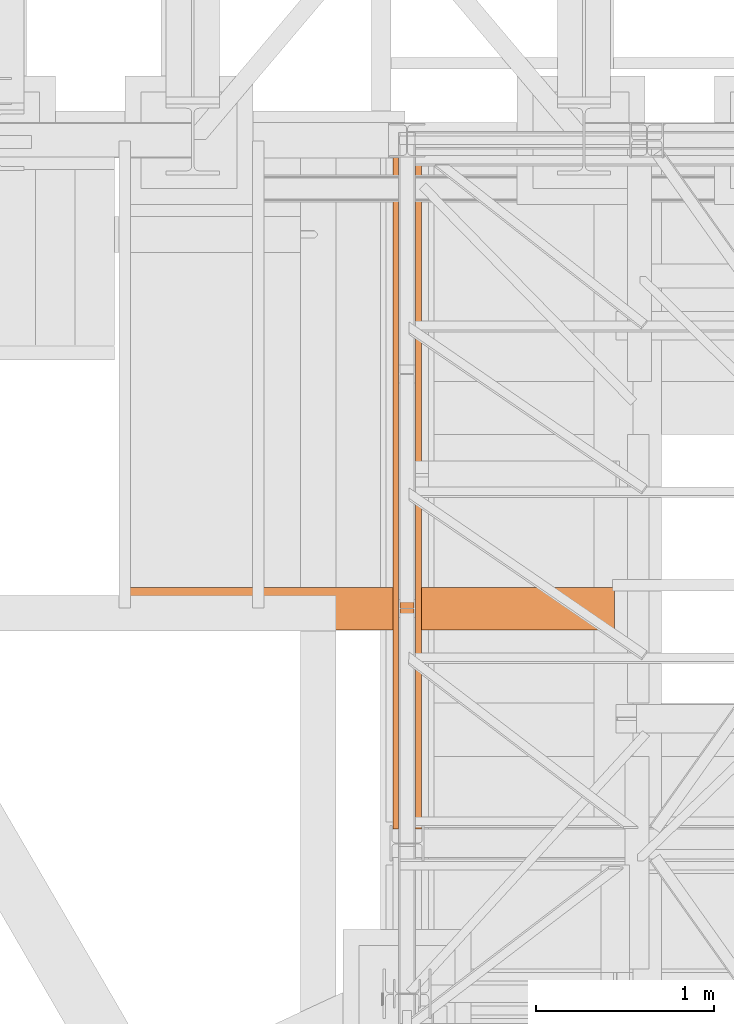
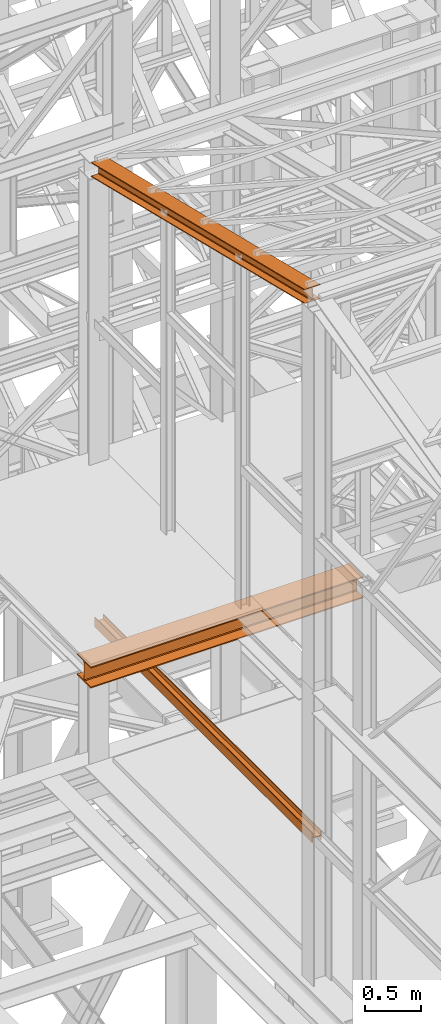
# One storey, part 26 of 208: 3 proxies.
"""IFC2X3 building model written with IfcOpenShell, lengths in millimetres."""

from ifc_helpers import new_model, entity, si_unit, converted_unit, frame, origin, origin_with_axes, place, context, subcontext, project, spatial, faceted_brep, element, save


model = new_model("IFC2X3")

# Units and contexts
model_context = context("Model", 3, precision=1e-05, world=origin())
plan_context = context("Plan", 3, precision=1e-05, world=origin())
body_context = subcontext(model_context, "Body", "Model", "MODEL_VIEW")
ifc_project = project(units=[si_unit("LENGTHUNIT", "METRE", prefix="MILLI"), converted_unit("PLANEANGLEUNIT", "DEGREE", entity("IfcPlaneAngleMeasure", 0.0174532925199433), si_unit("PLANEANGLEUNIT", "RADIAN"), dimensions=[0, 0, 0, 0, 0, 0, 0]), si_unit("AREAUNIT", "SQUARE_METRE"), si_unit("VOLUMEUNIT", "CUBIC_METRE")], contexts=[model_context, plan_context])

# Building, storey
building_placement = place(None, origin())
building = spatial("IfcBuilding", under=ifc_project, at=building_placement, CompositionType="COMPLEX")
storey_placement = place(building_placement, origin_with_axes())
storey = spatial("IfcBuildingStorey", under=building, at=storey_placement, Name="Geschoss", CompositionType="ELEMENT")

# Proxies
proxy_1_placement = place(storey_placement, frame((1150.254968144219, -21214.32439025083, 6759.989999254943), z_axis=(0.0, 0.0, 1.0), x_axis=(1.0, 0.0, 0.0)))
element("IfcBuildingElementProxy", 1, at=proxy_1_placement, inside=storey, context=body_context, shape_type="Brep", body=[
    faceted_brep([(8.010000000000218, 0.00999999999839929, 0.01000000000021828), (0.01000000000021828, 0.00999999999839929, 0.01000000000021828), (0.01000000000021828, 0.00999999999839929, 100.0100000000002), (8.010000000000218, 0.00999999999839929, 100.0100000000002), (8.010000000000218, 0.00999999999839929, 52.51000000000022), (88.01000000000022, 0.00999999999839929, 52.51000000000022), (88.01000000000022, 0.00999999999839929, 100.0100000000002), (96.00999999999999, 0.00999999999839929, 100.0100000000002), (96.00999999999999, 0.00999999999839929, 0.01000000000021828), (88.01000000000022, 0.00999999999839929, 0.01000000000021828), (88.01000000000022, 0.00999999999839929, 47.51000000000022), (8.010000000000218, 0.00999999999839929, 47.51000000000022), (0.01000000000021828, 0.00999999999839929, 0.01000000000021828), (8.010000000000218, 0.00999999999839929, 0.01000000000021828), (8.010000000000673, 3856.759984999411, 0.01000000000021828), (0.01000000000067303, 3856.759984999411, 0.01000000000021828), (0.01000000000021828, 0.00999999999839929, 100.0100000000002), (0.01000000000021828, 0.00999999999839929, 0.01000000000021828), (0.01000000000067303, 3856.759984999411, 0.01000000000021828), (0.01000000000067303, 3856.759984999411, 100.0100000000002), (8.010000000000218, 0.00999999999839929, 100.0100000000002), (0.01000000000021828, 0.00999999999839929, 100.0100000000002), (0.01000000000067303, 3856.759984999411, 100.0100000000002), (8.010000000000673, 3856.759984999411, 100.0100000000002), (8.010000000000218, 0.00999999999839929, 52.51000000000022), (8.010000000000218, 0.00999999999839929, 100.0100000000002), (8.010000000000673, 3856.759984999411, 100.0100000000002), (8.010000000000673, 3856.759984999411, 52.51000000000022), (88.01000000000022, 0.00999999999839929, 52.51000000000022), (8.010000000000218, 0.00999999999839929, 52.51000000000022), (8.010000000000673, 3856.759984999411, 52.51000000000022), (88.01000000000067, 3856.759984999411, 52.51000000000022), (88.01000000000022, 0.00999999999839929, 100.0100000000002), (88.01000000000022, 0.00999999999839929, 52.51000000000022), (88.01000000000067, 3856.759984999411, 52.51000000000022), (88.01000000000067, 3856.759984999411, 100.0100000000002), (96.00999999999999, 0.00999999999839929, 100.0100000000002), (88.01000000000022, 0.00999999999839929, 100.0100000000002), (88.01000000000067, 3856.759984999411, 100.0100000000002), (96.01000000000045, 3856.759984999411, 100.0100000000002), (96.00999999999999, 0.00999999999839929, 0.01000000000021828), (96.00999999999999, 0.00999999999839929, 100.0100000000002), (96.01000000000045, 3856.759984999411, 100.0100000000002), (96.01000000000045, 3856.759984999411, 0.01000000000021828), (88.01000000000022, 0.00999999999839929, 0.01000000000021828), (96.00999999999999, 0.00999999999839929, 0.01000000000021828), (96.01000000000045, 3856.759984999411, 0.01000000000021828), (88.01000000000067, 3856.759984999411, 0.01000000000021828), (88.01000000000022, 0.00999999999839929, 47.51000000000022), (88.01000000000022, 0.00999999999839929, 0.01000000000021828), (88.01000000000067, 3856.759984999411, 0.01000000000021828), (88.01000000000067, 3856.759984999411, 47.51000000000022), (8.010000000000218, 0.00999999999839929, 47.51000000000022), (88.01000000000022, 0.00999999999839929, 47.51000000000022), (88.01000000000067, 3856.759984999411, 47.51000000000022), (8.010000000000673, 3856.759984999411, 47.51000000000022), (8.010000000000218, 0.00999999999839929, 0.01000000000021828), (8.010000000000218, 0.00999999999839929, 47.51000000000022), (8.010000000000673, 3856.759984999411, 47.51000000000022), (8.010000000000673, 3856.759984999411, 0.01000000000021828), (8.010000000000673, 3856.759984999411, 0.01000000000021828), (8.010000000000673, 3856.759984999411, 47.51000000000022), (88.01000000000067, 3856.759984999411, 47.51000000000022), (88.01000000000067, 3856.759984999411, 0.01000000000021828), (96.01000000000045, 3856.759984999411, 0.01000000000021828), (96.01000000000045, 3856.759984999411, 100.0100000000002), (88.01000000000067, 3856.759984999411, 100.0100000000002), (88.01000000000067, 3856.759984999411, 52.51000000000022), (8.010000000000673, 3856.759984999411, 52.51000000000022), (8.010000000000673, 3856.759984999411, 100.0100000000002), (0.01000000000067303, 3856.759984999411, 100.0100000000002), (0.01000000000067303, 3856.759984999411, 0.01000000000021828)], [[[0, 1, 2, 3, 4, 5, 6, 7, 8, 9, 10, 11]], [[12, 13, 14, 15]], [[16, 17, 18, 19]], [[20, 21, 22, 23]], [[24, 25, 26, 27]], [[28, 29, 30, 31]], [[32, 33, 34, 35]], [[36, 37, 38, 39]], [[40, 41, 42, 43]], [[44, 45, 46, 47]], [[48, 49, 50, 51]], [[52, 53, 54, 55]], [[56, 57, 58, 59]], [[60, 61, 62, 63, 64, 65, 66, 67, 68, 69, 70, 71]]], orient=[[False], [False], [False], [False], [False], [False], [False], [False], [False], [False], [False], [False], [False], [False]]),
])
proxy_2_placement = place(storey_placement, frame((-421.7450362397046, -20018.66159598975, 8254.989997913835), z_axis=(0.0, 0.0, 1.0), x_axis=(1.0, 0.0, 0.0)))
element("IfcBuildingElementProxy", 2, at=proxy_2_placement, inside=storey, context=body_context, shape_type="Brep", body=[
    faceted_brep([(0.009999999999990905, 240.0100095367452, 230.0100041723217), (2786.26000461936, 241.0972092643315, 230.0100041723217), (2786.260004619361, 1.097199727588304, 230.0100041723217), (0.009999999999990905, 0.01000000000203727, 230.0100041723217), (0.009999999999990905, 0.01000000000203727, 230.0100041723217), (2786.260004619361, 1.097199727588304, 230.0100041723217), (2786.260004619361, 1.097199727588304, 218.0100022053684), (0.009999999999990905, 0.01000000000203727, 218.0100022053684), (0.009999999999990905, 0.01000000000203727, 218.0100022053684), (2786.260004619361, 1.097199727588304, 218.0100022053684), (2786.260004619361, 96.34720276742519, 218.0100022053684), (0.009999999999990905, 95.26000303983892, 218.0100022053684), (0.009999999999990905, 95.26000303983892, 218.0100022053684), (2786.260004619361, 96.34720276742519, 218.0100022053684), (2786.260004619361, 107.2156487375432, 215.8347008919682), (0.009999999999990905, 106.128449009957, 215.8347008919682), (0.009999999999990905, 106.128449009957, 215.8347008919682), (2786.260004619361, 107.2156487375432, 215.8347008919682), (2786.260004619361, 115.1718983769351, 207.8784493899311), (0.009999999999990905, 114.0846986493489, 207.8784493899311), (0.009999999999990905, 114.0846986493489, 207.8784493899311), (2786.260004619361, 115.1718983769351, 207.8784493899311), (2786.260004619361, 117.3472043469483, 197.0100043511357), (0.009999999999990905, 116.260004619362, 197.0100043511357), (0.009999999999990905, 116.260004619362, 197.0100043511357), (2786.260004619361, 117.3472043469483, 197.0100043511357), (2786.260004619361, 117.3472043469483, 33.00999982118628), (0.009999999999990905, 116.260004619362, 33.00999982118628), (0.009999999999990905, 116.260004619362, 33.00999982118628), (2786.260004619361, 117.3472043469483, 33.00999982118628), (2786.260004619361, 115.1718983769351, 22.14155478239081), (0.009999999999990905, 114.0846986493489, 22.14155478239081), (0.009999999999990905, 114.0846986493489, 22.14155478239081), (2786.260004619361, 115.1718983769351, 22.14155478239081), (2786.260004619361, 107.2156487375432, 14.18530328035376), (0.009999999999990905, 106.128449009957, 14.18530328035376), (0.009999999999990905, 106.128449009957, 14.18530328035376), (2786.260004619361, 107.2156487375432, 14.18530328035376), (2786.260004619361, 96.34720276742519, 12.0100019669535), (0.009999999999990905, 95.26000303983892, 12.0100019669535), (0.009999999999990905, 95.26000303983892, 12.0100019669535), (2786.260004619361, 96.34720276742519, 12.0100019669535), (2786.260004619361, 1.097199727588304, 12.0100019669535), (0.009999999999990905, 0.01000000000203727, 12.0100019669535), (0.009999999999990905, 0.01000000000203727, 12.0100019669535), (2786.260004619361, 1.097199727588304, 12.0100019669535), (2786.260004619361, 1.097199727588304, 0.01000000000021828), (0.009999999999990905, 0.01000000000203727, 0.01000000000021828), (0.009999999999990905, 0.01000000000203727, 0.01000000000021828), (2786.260004619361, 1.097199727588304, 0.01000000000021828), (2786.26000461936, 241.0972092643315, 0.00999999999839929), (0.009999999999990905, 240.0100095367452, 0.01000000000021828), (0.009999999999990905, 240.0100095367452, 0.01000000000021828), (2786.26000461936, 241.0972092643315, 0.00999999999839929), (2786.26000461936, 241.0972092643315, 12.0100019669535), (0.009999999999990905, 240.0100095367452, 12.0100019669535), (0.009999999999990905, 240.0100095367452, 12.0100019669535), (2786.26000461936, 241.0972092643315, 12.0100019669535), (2786.260004619361, 145.8472062244946, 12.0100019669535), (0.009999999999990905, 144.7600064969083, 12.0100019669535), (0.009999999999990905, 144.7600064969083, 12.0100019669535), (2786.260004619361, 145.8472062244946, 12.0100019669535), (2786.260004619361, 134.9787602543765, 14.18530328035376), (0.009999999999990905, 133.8915605267903, 14.18530328035376), (0.009999999999990905, 133.8915605267903, 14.18530328035376), (2786.260004619361, 134.9787602543765, 14.18530328035376), (2786.260004619361, 127.0225106149846, 22.14155478239081), (0.009999999999990905, 125.9353108873947, 22.14155478239081), (0.009999999999990905, 125.9353108873947, 22.14155478239081), (2786.260004619361, 127.0225106149846, 22.14155478239081), (2786.260004619361, 124.8472046449715, 33.00999982118628), (0.009999999999990905, 123.7600049173852, 33.00999982118628), (0.009999999999990905, 123.7600049173852, 33.00999982118628), (2786.260004619361, 124.8472046449715, 33.00999982118628), (2786.260004619361, 124.8472046449715, 197.0100043511357), (0.009999999999990905, 123.7600049173852, 197.0100043511357), (0.009999999999990905, 123.7600049173852, 197.0100043511357), (2786.260004619361, 124.8472046449715, 197.0100043511357), (2786.260004619361, 127.0225106149846, 207.8784493899311), (0.009999999999990905, 125.9353108873947, 207.8784493899311), (0.009999999999990905, 125.9353108873947, 207.8784493899311), (2786.260004619361, 127.0225106149846, 207.8784493899311), (2786.260004619361, 134.9787602543765, 215.8347008919682), (0.009999999999990905, 133.8915605267903, 215.8347008919682), (0.009999999999990905, 133.8915605267903, 215.8347008919682), (2786.260004619361, 134.9787602543765, 215.8347008919682), (2786.260004619361, 145.8472062244946, 218.0100022053684), (0.009999999999990905, 144.7600064969083, 218.0100022053684), (0.009999999999990905, 144.7600064969083, 218.0100022053684), (2786.260004619361, 145.8472062244946, 218.0100022053684), (2786.26000461936, 241.0972092643315, 218.0100022053684), (0.009999999999990905, 240.0100095367452, 218.0100022053684), (0.009999999999990905, 240.0100095367452, 218.0100022053684), (2786.26000461936, 241.0972092643315, 218.0100022053684), (2786.26000461936, 241.0972092643315, 230.0100041723217), (0.009999999999990905, 240.0100095367452, 230.0100041723217), (2786.260004619361, 145.8472062244946, 218.0100022053684), (2786.260004619361, 134.9787602543765, 215.8347008919682), (2786.260004619361, 127.0225106149846, 207.8784493899311), (2786.260004619361, 124.8472046449715, 197.0100043511357), (2786.260004619361, 124.8472046449715, 33.00999982118628), (2786.260004619361, 127.0225106149846, 22.14155478239081), (2786.260004619361, 134.9787602543765, 14.18530328035376), (2786.260004619361, 145.8472062244946, 12.0100019669535), (2786.26000461936, 241.0972092643315, 12.0100019669535), (2786.26000461936, 241.0972092643315, 0.00999999999839929), (2786.260004619361, 1.097199727588304, 0.01000000000021828), (2786.260004619361, 1.097199727588304, 12.0100019669535), (2786.260004619361, 96.34720276742519, 12.0100019669535), (2786.260004619361, 107.2156487375432, 14.18530328035376), (2786.260004619361, 115.1718983769351, 22.14155478239081), (2786.260004619361, 117.3472043469483, 33.00999982118628), (2786.260004619361, 117.3472043469483, 197.0100043511357), (2786.260004619361, 115.1718983769351, 207.8784493899311), (2786.260004619361, 107.2156487375432, 215.8347008919682), (2786.260004619361, 96.34720276742519, 218.0100022053684), (2786.260004619361, 1.097199727588304, 218.0100022053684), (2786.260004619361, 1.097199727588304, 230.0100041723217), (2786.26000461936, 241.0972092643315, 230.0100041723217), (2786.26000461936, 241.0972092643315, 218.0100022053684), (0.009999999999990905, 0.01000000000203727, 230.0100041723217), (0.009999999999990905, 0.01000000000203727, 218.0100022053684), (0.009999999999990905, 95.26000303983892, 218.0100022053684), (0.009999999999990905, 106.128449009957, 215.8347008919682), (0.009999999999990905, 114.0846986493489, 207.8784493899311), (0.009999999999990905, 116.260004619362, 197.0100043511357), (0.009999999999990905, 116.260004619362, 33.00999982118628), (0.009999999999990905, 114.0846986493489, 22.14155478239081), (0.009999999999990905, 106.128449009957, 14.18530328035376), (0.009999999999990905, 95.26000303983892, 12.0100019669535), (0.009999999999990905, 0.01000000000203727, 12.0100019669535), (0.009999999999990905, 0.01000000000203727, 0.01000000000021828), (0.009999999999990905, 240.0100095367452, 0.01000000000021828), (0.009999999999990905, 240.0100095367452, 12.0100019669535), (0.009999999999990905, 144.7600064969083, 12.0100019669535), (0.009999999999990905, 133.8915605267903, 14.18530328035376), (0.009999999999990905, 125.9353108873947, 22.14155478239081), (0.009999999999990905, 123.7600049173852, 33.00999982118628), (0.009999999999990905, 123.7600049173852, 197.0100043511357), (0.009999999999990905, 125.9353108873947, 207.8784493899311), (0.009999999999990905, 133.8915605267903, 215.8347008919682), (0.009999999999990905, 144.7600064969083, 218.0100022053684), (0.009999999999990905, 240.0100095367452, 218.0100022053684), (0.009999999999990905, 240.0100095367452, 230.0100041723217)], [[[0, 1, 2, 3]], [[4, 5, 6, 7]], [[8, 9, 10, 11]], [[12, 13, 14, 15]], [[16, 17, 18, 19]], [[20, 21, 22, 23]], [[24, 25, 26, 27]], [[28, 29, 30, 31]], [[32, 33, 34, 35]], [[36, 37, 38, 39]], [[40, 41, 42, 43]], [[44, 45, 46, 47]], [[48, 49, 50, 51]], [[52, 53, 54, 55]], [[56, 57, 58, 59]], [[60, 61, 62, 63]], [[64, 65, 66, 67]], [[68, 69, 70, 71]], [[72, 73, 74, 75]], [[76, 77, 78, 79]], [[80, 81, 82, 83]], [[84, 85, 86, 87]], [[88, 89, 90, 91]], [[92, 93, 94, 95]], [[96, 97, 98, 99, 100, 101, 102, 103, 104, 105, 106, 107, 108, 109, 110, 111, 112, 113, 114, 115, 116, 117, 118, 119]], [[120, 121, 122, 123, 124, 125, 126, 127, 128, 129, 130, 131, 132, 133, 134, 135, 136, 137, 138, 139, 140, 141, 142, 143]]], orient=[[False], [False], [False], [False], [False], [False], [False], [False], [False], [False], [False], [False], [False], [False], [False], [False], [False], [False], [False], [False], [False], [False], [False], [False], [False], [False]]),
])
proxy_3_placement = place(storey_placement, frame((1118.254966591504, -21137.57438465544, 11628.70515179705), z_axis=(0.0, 0.0, 1.0), x_axis=(1.0, 0.0, 0.0)))
element("IfcBuildingElementProxy", 3, at=proxy_3_placement, inside=storey, context=body_context, shape_type="Brep", body=[
    faceted_brep([(160.010011324888, 0.00999999999839929, 1074.775244917653), (0.01000000000544787, 0.00999999999839929, 1074.775244917653), (0.009999999999990905, 3780.009979404022, 156.4315054631916), (160.0100113248798, 3780.009979404022, 156.4315054631916), (0.01000000000544787, 0.00999999999839929, 1074.775244917653), (0.01000000000544787, 0.00999999999839929, 1065.513442427271), (0.009999999999990905, 3780.009979404025, 147.1697029728093), (0.009999999999990905, 3780.009979404022, 156.4315054631916), (0.01000000000544787, 0.00999999999839929, 1065.513442427271), (62.01000457466193, 0.00999999999839929, 1065.513442427271), (62.01000457465648, 3780.009979404025, 147.1697029728093), (0.009999999999990905, 3780.009979404025, 147.1697029728093), (62.01000457466193, 0.00999999999839929, 1065.513442427271), (69.77318079978772, 0.00999999999839929, 1063.914455819968), (69.77318079977863, 3780.009979404025, 145.5707163655079), (62.01000457465648, 3780.009979404025, 147.1697029728093), (69.77318079978772, 0.00999999999839929, 1063.914455819968), (75.45621545821973, 0.00999999999839929, 1058.066108594254), (75.45621545821064, 3780.009979404025, 139.7223691397903), (69.77318079977863, 3780.009979404025, 145.5707163655079), (75.45621545821973, 0.00999999999839929, 1058.066108594254), (77.01000563636967, 0.00999999999839929, 1050.077113888498), (77.01000563636057, 3780.009979404025, 131.7333744340358), (75.45621545821064, 3780.009979404025, 139.7223691397903), (77.01000563636967, 0.00999999999839929, 1050.077113888498), (77.01000563636967, 0.00999999999839929, 943.0518743172743), (77.01000563636057, 3780.009979404025, 24.70813486281259), (77.01000563636057, 3780.009979404025, 131.7333744340358), (77.01000563636967, 0.00999999999839929, 943.0518743172743), (75.45621545821973, 0.00999999999839929, 935.0628757778613), (75.45621545821064, 3780.009979404025, 16.71913632339965), (77.01000563636057, 3780.009979404025, 24.70813486281259), (75.45621545821973, 0.00999999999839929, 935.0628757778613), (69.77318079978772, 0.00999999999839929, 929.2145285521474), (69.77318079977863, 3780.009979404025, 10.87078909768752), (75.45621545821064, 3780.009979404025, 16.71913632339965), (69.77318079978772, 0.00999999999839929, 929.2145285521474), (62.01000457466193, 0.00999999999839929, 927.6155419448442), (62.01000457465284, 3780.009979404025, 9.27180249038247), (69.77318079977863, 3780.009979404025, 10.87078909768752), (62.01000457466193, 0.00999999999839929, 927.6155419448442), (0.01000000000544787, 0.00999999999839929, 927.6155419448423), (0.009999999999990905, 3780.009979404025, 9.27180249038247), (62.01000457465284, 3780.009979404025, 9.27180249038247), (0.01000000000544787, 0.00999999999839929, 927.6155419448423), (0.01000000000544787, 0.00999999999839929, 918.3537394544601), (0.009999999999990905, 3780.009979404025, 0.01000000000021828), (0.009999999999990905, 3780.009979404025, 9.27180249038247), (0.01000000000544787, 0.00999999999839929, 918.3537394544601), (160.010011324888, 0.00999999999839929, 918.3537394544619), (160.0100113248825, 3780.009979404025, 0.01000000000021828), (0.009999999999990905, 3780.009979404025, 0.01000000000021828), (160.010011324888, 0.00999999999839929, 918.3537394544619), (160.010011324888, 0.00999999999839929, 927.6155419448423), (160.0100113248834, 3780.009979404025, 9.27180249038065), (160.0100113248825, 3780.009979404025, 0.01000000000021828), (160.010011324888, 0.00999999999839929, 927.6155419448423), (98.01000675023147, 0.00999999999839929, 927.6155419448423), (98.01000675022237, 3780.009979404025, 9.27180249038247), (160.0100113248834, 3780.009979404025, 9.27180249038065), (98.01000675023147, 0.00999999999839929, 927.6155419448423), (90.24683052510568, 0.00999999999839929, 929.2145285521474), (90.24683052509658, 3780.009979404025, 10.87078909768752), (98.01000675022237, 3780.009979404025, 9.27180249038247), (90.24683052510568, 0.00999999999839929, 929.2145285521474), (84.56379586667367, 0.00999999999839929, 935.0628757778613), (84.56379586666458, 3780.009979404025, 16.71913632339783), (90.24683052509658, 3780.009979404025, 10.87078909768752), (84.56379586667367, 0.00999999999839929, 935.0628757778613), (83.01000568852373, 0.00999999999839929, 943.0518743172743), (83.01000568851464, 3780.009979404025, 24.70813486281077), (84.56379586666458, 3780.009979404025, 16.71913632339783), (83.01000568852373, 0.00999999999839929, 943.0518743172743), (83.01000568852373, 0.00999999999839929, 1050.077113888496), (83.01000568851555, 3780.009979404025, 131.733374434034), (83.01000568851464, 3780.009979404025, 24.70813486281077), (83.01000568852373, 0.00999999999839929, 1050.077113888496), (84.56379586667367, 0.00999999999839929, 1058.066108594254), (84.56379586666458, 3780.009979404025, 139.7223691397903), (83.01000568851555, 3780.009979404025, 131.733374434034), (84.56379586667367, 0.00999999999839929, 1058.066108594254), (90.24683052510568, 0.00999999999839929, 1063.914455819968), (90.2468305250975, 3780.009979404025, 145.5707163655079), (84.56379586666458, 3780.009979404025, 139.7223691397903), (90.24683052510568, 0.00999999999839929, 1063.914455819968), (98.01000675023147, 0.00999999999839929, 1065.513442427271), (98.01000675022237, 3780.009979404025, 147.1697029728093), (90.2468305250975, 3780.009979404025, 145.5707163655079), (98.01000675023147, 0.00999999999839929, 1065.513442427271), (160.010011324888, 0.00999999999839929, 1065.513442427271), (160.0100113248834, 3780.009979404025, 147.1697029728093), (98.01000675022237, 3780.009979404025, 147.1697029728093), (160.010011324888, 0.00999999999839929, 1065.513442427271), (160.010011324888, 0.00999999999839929, 1074.775244917653), (160.0100113248798, 3780.009979404022, 156.4315054631916), (160.0100113248834, 3780.009979404025, 147.1697029728093), (0.01000000000544787, 0.00999999999839929, 1074.775244917653), (160.010011324888, 0.00999999999839929, 1074.775244917653), (160.010011324888, 0.00999999999839929, 1065.513442427271), (98.01000675023147, 0.00999999999839929, 1065.513442427271), (90.24683052510568, 0.00999999999839929, 1063.914455819968), (84.56379586667367, 0.00999999999839929, 1058.066108594254), (83.01000568852373, 0.00999999999839929, 1050.077113888496), (83.01000568852373, 0.00999999999839929, 943.0518743172743), (84.56379586667367, 0.00999999999839929, 935.0628757778613), (90.24683052510568, 0.00999999999839929, 929.2145285521474), (98.01000675023147, 0.00999999999839929, 927.6155419448423), (160.010011324888, 0.00999999999839929, 927.6155419448423), (160.010011324888, 0.00999999999839929, 918.3537394544619), (0.01000000000544787, 0.00999999999839929, 918.3537394544601), (0.01000000000544787, 0.00999999999839929, 927.6155419448423), (62.01000457466193, 0.00999999999839929, 927.6155419448442), (69.77318079978772, 0.00999999999839929, 929.2145285521474), (75.45621545821973, 0.00999999999839929, 935.0628757778613), (77.01000563636967, 0.00999999999839929, 943.0518743172743), (77.01000563636967, 0.00999999999839929, 1050.077113888498), (75.45621545821973, 0.00999999999839929, 1058.066108594254), (69.77318079978772, 0.00999999999839929, 1063.914455819968), (62.01000457466193, 0.00999999999839929, 1065.513442427271), (0.01000000000544787, 0.00999999999839929, 1065.513442427271), (160.0100113248798, 3780.009979404022, 156.4315054631916), (0.009999999999990905, 3780.009979404022, 156.4315054631916), (0.009999999999990905, 3780.009979404025, 147.1697029728093), (62.01000457465648, 3780.009979404025, 147.1697029728093), (69.77318079977863, 3780.009979404025, 145.5707163655079), (75.45621545821064, 3780.009979404025, 139.7223691397903), (77.01000563636057, 3780.009979404025, 131.7333744340358), (77.01000563636057, 3780.009979404025, 24.70813486281259), (75.45621545821064, 3780.009979404025, 16.71913632339965), (69.77318079977863, 3780.009979404025, 10.87078909768752), (62.01000457465284, 3780.009979404025, 9.27180249038247), (0.009999999999990905, 3780.009979404025, 9.27180249038247), (0.009999999999990905, 3780.009979404025, 0.01000000000021828), (160.0100113248825, 3780.009979404025, 0.01000000000021828), (160.0100113248834, 3780.009979404025, 9.27180249038065), (98.01000675022237, 3780.009979404025, 9.27180249038247), (90.24683052509658, 3780.009979404025, 10.87078909768752), (84.56379586666458, 3780.009979404025, 16.71913632339783), (83.01000568851464, 3780.009979404025, 24.70813486281077), (83.01000568851555, 3780.009979404025, 131.733374434034), (84.56379586666458, 3780.009979404025, 139.7223691397903), (90.2468305250975, 3780.009979404025, 145.5707163655079), (98.01000675022237, 3780.009979404025, 147.1697029728093), (160.0100113248834, 3780.009979404025, 147.1697029728093)], [[[0, 1, 2, 3]], [[4, 5, 6, 7]], [[8, 9, 10, 11]], [[12, 13, 14, 15]], [[16, 17, 18, 19]], [[20, 21, 22, 23]], [[24, 25, 26, 27]], [[28, 29, 30, 31]], [[32, 33, 34, 35]], [[36, 37, 38, 39]], [[40, 41, 42, 43]], [[44, 45, 46, 47]], [[48, 49, 50, 51]], [[52, 53, 54, 55]], [[56, 57, 58, 59]], [[60, 61, 62, 63]], [[64, 65, 66, 67]], [[68, 69, 70, 71]], [[72, 73, 74, 75]], [[76, 77, 78, 79]], [[80, 81, 82, 83]], [[84, 85, 86, 87]], [[88, 89, 90, 91]], [[92, 93, 94, 95]], [[96, 97, 98, 99, 100, 101, 102, 103, 104, 105, 106, 107, 108, 109, 110, 111, 112, 113, 114, 115, 116, 117, 118, 119]], [[120, 121, 122, 123, 124, 125, 126, 127, 128, 129, 130, 131, 132, 133, 134, 135, 136, 137, 138, 139, 140, 141, 142, 143]]], orient=[[False], [False], [False], [False], [False], [False], [False], [False], [False], [False], [False], [False], [False], [False], [False], [False], [False], [False], [False], [False], [False], [False], [False], [False], [False], [False]]),
])

save(model, "model.ifc")
